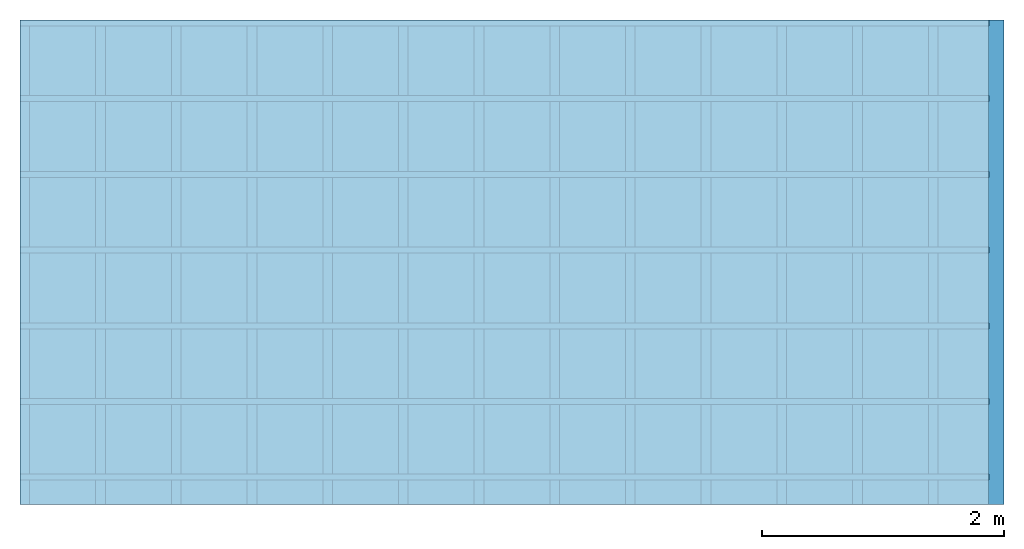
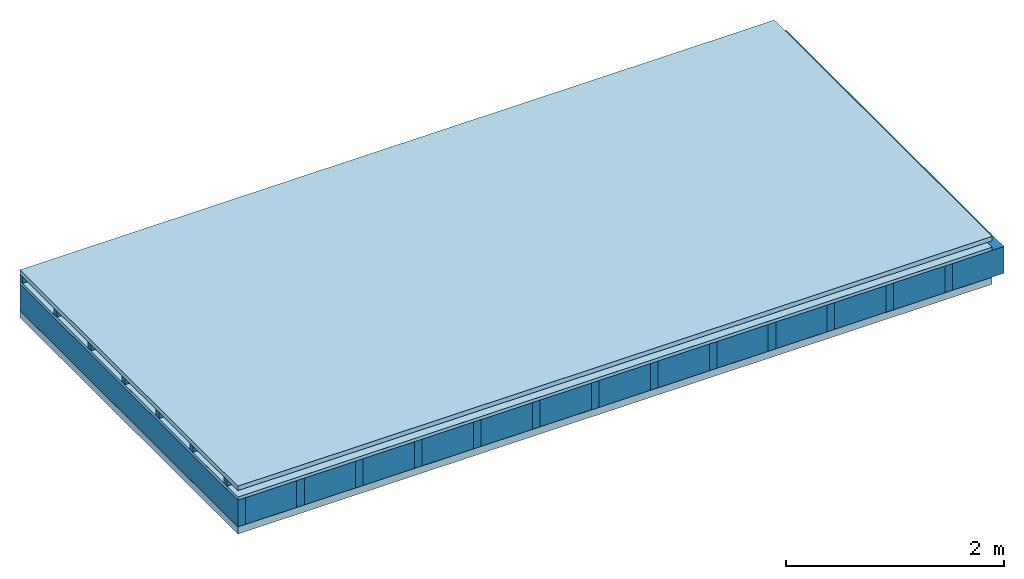
# One storey: 5 plates, 3 members, 1 element without a shape of its own.
"""IFC4 building model written with IfcOpenShell, lengths in metres."""

from ifc_helpers import new_model, si_unit, derived_unit, direction, frame, frame_2d, origin, origin_with_axes, place, context, project, spatial, rectangle, extrude, material, layer, layer_set, type_object, element, aggregate, save


model = new_model("IFC4")

# Units and contexts
plan_context = context("Plan", 3, precision=1e-05, world=origin(), true_north=direction((0.0, 1.0)))
model_context = context("Model", 3, precision=1e-05, world=origin(), true_north=direction((0.0, 1.0)))
ifc_project = project(units=[si_unit("LENGTHUNIT", "METRE"), derived_unit("SOUNDPRESSUREUNIT", [(si_unit("PRESSUREUNIT", "PASCAL", prefix="MICRO"), 0)]), si_unit("ENERGYUNIT", "JOULE", prefix="MEGA"), si_unit("MASSUNIT", "GRAM", prefix="KILO"), derived_unit("THERMALTRANSMITTANCEUNIT", [(si_unit("POWERUNIT", "WATT"), 1), (si_unit("AREAUNIT", "SQUARE_METRE"), -1), (si_unit("THERMODYNAMICTEMPERATUREUNIT", "KELVIN"), -1)]), derived_unit("AREADENSITYUNIT", [(si_unit("MASSUNIT", "GRAM", prefix="KILO"), 1), (si_unit("AREAUNIT", "SQUARE_METRE"), -1)]), derived_unit("USERDEFINED", [(si_unit("ENERGYUNIT", "JOULE", prefix="MEGA"), 1), (si_unit("AREAUNIT", "SQUARE_METRE"), -1)])], contexts=[plan_context, model_context])

# Site, building, storey
site = spatial("IfcSite", under=ifc_project)
building_placement = place(None, origin())
building = spatial("IfcBuilding", under=site, at=building_placement)
storey_placement = place(building_placement, origin())
storey = spatial("IfcBuildingStorey", under=building, at=storey_placement)

# Slab, members, plates
ifc_material_1 = material(Name="Roof tiles", Category="03.015")
ifc_layer_1 = layer(ifc_material_1, 0.05, Name="Roofing")
ifc_layer_2 = layer(None, 0.072, Name="Battens / profiles")
ifc_material_2 = material(Name="Roofing underlay", Category="09.008")
ifc_layer_3 = layer(ifc_material_2, 0.00018, Name="Under the roof")
ifc_material_3 = material(Category="10.009")
ifc_layer_4 = layer(ifc_material_3, 0.035, Name="Sub-floor")
ifc_material_4 = material(Name="of the art")
ifc_layer_5 = layer(ifc_material_4, 0.0, Name="Bond")
ifc_layer_6 = layer(None, 0.3, Name="Supporting structure")
ifc_material_5 = material(Name="Vapor barrier polyethylene (PE)", Category="09.002")
ifc_layer_7 = layer(ifc_material_5, 0.00025, Name="Lower layer 1")
ifc_material_6 = material(Name="Solid timber panel")
ifc_layer_8 = layer(ifc_material_6, 0.08, Name="Lower 2nd layer")
ifc_layer_set = layer_set([ifc_layer_1, ifc_layer_2, ifc_layer_3, ifc_layer_4, ifc_layer_5, ifc_layer_6, ifc_layer_7, ifc_layer_8])
slab_type = type_object("IfcSlabType", Name="E0155", PredefinedType="NOTDEFINED", material=ifc_layer_set)
slab_placement = place(None, frame((0.0, 0.0, 0.0), z_axis=(0.0, 0.0, -1.0), x_axis=(1.0, 0.0, 0.0)))
slab = element("IfcSlab", 1, at=slab_placement, inside=storey, type_object=slab_type, material=ifc_layer_set, Name="Slab #1")
ifc_material_7 = material()
member_1_placement = place(slab_placement, origin())
member_1 = element("IfcMember", 2, at=member_1_placement, material=ifc_material_7, Name="Battens / profiles", context=plan_context, shape_type="SweptSolid", body=[
    extrude(rectangle(XDim=0.05, YDim=0.072, at=frame_2d((0.025, 0.036), x_axis=(1.0, 0.0))), frame((0.0, 0.0, 0.05), z_axis=(1.0, 0.0, 0.0), x_axis=(0.0, 1.0, 0.0)), (0.0, 0.0, 1.0), 8.0),
    extrude(rectangle(XDim=0.05, YDim=0.072, at=frame_2d((0.025, 0.036), x_axis=(1.0, 0.0))), frame((0.0, 0.625, 0.05), z_axis=(1.0, 0.0, 0.0), x_axis=(0.0, 1.0, 0.0)), (0.0, 0.0, 1.0), 8.0),
    extrude(rectangle(XDim=0.05, YDim=0.072, at=frame_2d((0.025, 0.036), x_axis=(1.0, 0.0))), frame((0.0, 1.25, 0.05), z_axis=(1.0, 0.0, 0.0), x_axis=(0.0, 1.0, 0.0)), (0.0, 0.0, 1.0), 8.0),
    extrude(rectangle(XDim=0.05, YDim=0.072, at=frame_2d((0.025, 0.036), x_axis=(1.0, 0.0))), frame((0.0, 1.875, 0.05), z_axis=(1.0, 0.0, 0.0), x_axis=(0.0, 1.0, 0.0)), (0.0, 0.0, 1.0), 8.0),
    extrude(rectangle(XDim=0.05, YDim=0.072, at=frame_2d((0.025, 0.036), x_axis=(1.0, 0.0))), frame((0.0, 2.5, 0.05), z_axis=(1.0, 0.0, 0.0), x_axis=(0.0, 1.0, 0.0)), (0.0, 0.0, 1.0), 8.0),
    extrude(rectangle(XDim=0.05, YDim=0.072, at=frame_2d((0.025, 0.036), x_axis=(1.0, 0.0))), frame((0.0, 3.125, 0.05), z_axis=(1.0, 0.0, 0.0), x_axis=(0.0, 1.0, 0.0)), (0.0, 0.0, 1.0), 8.0),
    extrude(rectangle(XDim=0.05, YDim=0.072, at=frame_2d((0.025, 0.036), x_axis=(1.0, 0.0))), frame((0.0, 3.75, 0.05), z_axis=(1.0, 0.0, 0.0), x_axis=(0.0, 1.0, 0.0)), (0.0, 0.0, 1.0), 8.0),
])
ifc_material_8 = material()
member_2_placement = place(slab_placement, origin())
member_2 = element("IfcMember", 3, at=member_2_placement, material=ifc_material_8, Name="Supporting structure", context=plan_context, shape_type="SweptSolid", body=[
    extrude(rectangle(XDim=0.08, YDim=0.3, at=frame_2d((0.04, 0.15), x_axis=(1.0, 0.0))), frame((0.0, 4.0, 0.15718), z_axis=(0.0, -1.0, 0.0), x_axis=(1.0, 0.0, 0.0)), (0.0, 0.0, 1.0), 4.0),
    extrude(rectangle(XDim=0.08, YDim=0.3, at=frame_2d((0.04, 0.15), x_axis=(1.0, 0.0))), frame((0.625, 4.0, 0.15718), z_axis=(0.0, -1.0, 0.0), x_axis=(1.0, 0.0, 0.0)), (0.0, 0.0, 1.0), 4.0),
    extrude(rectangle(XDim=0.08, YDim=0.3, at=frame_2d((0.04, 0.15), x_axis=(1.0, 0.0))), frame((1.25, 4.0, 0.15718), z_axis=(0.0, -1.0, 0.0), x_axis=(1.0, 0.0, 0.0)), (0.0, 0.0, 1.0), 4.0),
    extrude(rectangle(XDim=0.08, YDim=0.3, at=frame_2d((0.04, 0.15), x_axis=(1.0, 0.0))), frame((1.875, 4.0, 0.15718), z_axis=(0.0, -1.0, 0.0), x_axis=(1.0, 0.0, 0.0)), (0.0, 0.0, 1.0), 4.0),
    extrude(rectangle(XDim=0.08, YDim=0.3, at=frame_2d((0.04, 0.15), x_axis=(1.0, 0.0))), frame((2.5, 4.0, 0.15718), z_axis=(0.0, -1.0, 0.0), x_axis=(1.0, 0.0, 0.0)), (0.0, 0.0, 1.0), 4.0),
    extrude(rectangle(XDim=0.08, YDim=0.3, at=frame_2d((0.04, 0.15), x_axis=(1.0, 0.0))), frame((3.125, 4.0, 0.15718), z_axis=(0.0, -1.0, 0.0), x_axis=(1.0, 0.0, 0.0)), (0.0, 0.0, 1.0), 4.0),
    extrude(rectangle(XDim=0.08, YDim=0.3, at=frame_2d((0.04, 0.15), x_axis=(1.0, 0.0))), frame((3.75, 4.0, 0.15718), z_axis=(0.0, -1.0, 0.0), x_axis=(1.0, 0.0, 0.0)), (0.0, 0.0, 1.0), 4.0),
    extrude(rectangle(XDim=0.08, YDim=0.3, at=frame_2d((0.04, 0.15), x_axis=(1.0, 0.0))), frame((4.375, 4.0, 0.15718), z_axis=(0.0, -1.0, 0.0), x_axis=(1.0, 0.0, 0.0)), (0.0, 0.0, 1.0), 4.0),
    extrude(rectangle(XDim=0.08, YDim=0.3, at=frame_2d((0.04, 0.15), x_axis=(1.0, 0.0))), frame((5.0, 4.0, 0.15718), z_axis=(0.0, -1.0, 0.0), x_axis=(1.0, 0.0, 0.0)), (0.0, 0.0, 1.0), 4.0),
    extrude(rectangle(XDim=0.08, YDim=0.3, at=frame_2d((0.04, 0.15), x_axis=(1.0, 0.0))), frame((5.625, 4.0, 0.15718), z_axis=(0.0, -1.0, 0.0), x_axis=(1.0, 0.0, 0.0)), (0.0, 0.0, 1.0), 4.0),
    extrude(rectangle(XDim=0.08, YDim=0.3, at=frame_2d((0.04, 0.15), x_axis=(1.0, 0.0))), frame((6.25, 4.0, 0.15718), z_axis=(0.0, -1.0, 0.0), x_axis=(1.0, 0.0, 0.0)), (0.0, 0.0, 1.0), 4.0),
    extrude(rectangle(XDim=0.08, YDim=0.3, at=frame_2d((0.04, 0.15), x_axis=(1.0, 0.0))), frame((6.875, 4.0, 0.15718), z_axis=(0.0, -1.0, 0.0), x_axis=(1.0, 0.0, 0.0)), (0.0, 0.0, 1.0), 4.0),
    extrude(rectangle(XDim=0.08, YDim=0.3, at=frame_2d((0.04, 0.15), x_axis=(1.0, 0.0))), frame((7.5, 4.0, 0.15718), z_axis=(0.0, -1.0, 0.0), x_axis=(1.0, 0.0, 0.0)), (0.0, 0.0, 1.0), 4.0),
])
ifc_material_9 = material(Name="Mineral wool")
member_3_placement = place(slab_placement, origin())
member_3 = element("IfcMember", 4, at=member_3_placement, material=ifc_material_9, Name="Cavity", context=plan_context, shape_type="SweptSolid", body=[
    extrude(rectangle(XDim=0.545, YDim=0.3, at=frame_2d((0.2725, 0.15), x_axis=(1.0, 0.0))), frame((0.08, 4.0, 0.15718), z_axis=(0.0, -1.0, 0.0), x_axis=(1.0, 0.0, 0.0)), (0.0, 0.0, 1.0), 4.0),
    extrude(rectangle(XDim=0.545, YDim=0.3, at=frame_2d((0.2725, 0.15), x_axis=(1.0, 0.0))), frame((0.705, 4.0, 0.15718), z_axis=(0.0, -1.0, 0.0), x_axis=(1.0, 0.0, 0.0)), (0.0, 0.0, 1.0), 4.0),
    extrude(rectangle(XDim=0.545, YDim=0.3, at=frame_2d((0.2725, 0.15), x_axis=(1.0, 0.0))), frame((1.33, 4.0, 0.15718), z_axis=(0.0, -1.0, 0.0), x_axis=(1.0, 0.0, 0.0)), (0.0, 0.0, 1.0), 4.0),
    extrude(rectangle(XDim=0.545, YDim=0.3, at=frame_2d((0.2725, 0.15), x_axis=(1.0, 0.0))), frame((1.955, 4.0, 0.15718), z_axis=(0.0, -1.0, 0.0), x_axis=(1.0, 0.0, 0.0)), (0.0, 0.0, 1.0), 4.0),
    extrude(rectangle(XDim=0.545, YDim=0.3, at=frame_2d((0.2725, 0.15), x_axis=(1.0, 0.0))), frame((2.58, 4.0, 0.15718), z_axis=(0.0, -1.0, 0.0), x_axis=(1.0, 0.0, 0.0)), (0.0, 0.0, 1.0), 4.0),
    extrude(rectangle(XDim=0.545, YDim=0.3, at=frame_2d((0.2725, 0.15), x_axis=(1.0, 0.0))), frame((3.205, 4.0, 0.15718), z_axis=(0.0, -1.0, 0.0), x_axis=(1.0, 0.0, 0.0)), (0.0, 0.0, 1.0), 4.0),
    extrude(rectangle(XDim=0.545, YDim=0.3, at=frame_2d((0.2725, 0.15), x_axis=(1.0, 0.0))), frame((3.83, 4.0, 0.15718), z_axis=(0.0, -1.0, 0.0), x_axis=(1.0, 0.0, 0.0)), (0.0, 0.0, 1.0), 4.0),
    extrude(rectangle(XDim=0.545, YDim=0.3, at=frame_2d((0.2725, 0.15), x_axis=(1.0, 0.0))), frame((4.455, 4.0, 0.15718), z_axis=(0.0, -1.0, 0.0), x_axis=(1.0, 0.0, 0.0)), (0.0, 0.0, 1.0), 4.0),
    extrude(rectangle(XDim=0.545, YDim=0.3, at=frame_2d((0.2725, 0.15), x_axis=(1.0, 0.0))), frame((5.08, 4.0, 0.15718), z_axis=(0.0, -1.0, 0.0), x_axis=(1.0, 0.0, 0.0)), (0.0, 0.0, 1.0), 4.0),
    extrude(rectangle(XDim=0.545, YDim=0.3, at=frame_2d((0.2725, 0.15), x_axis=(1.0, 0.0))), frame((5.705, 4.0, 0.15718), z_axis=(0.0, -1.0, 0.0), x_axis=(1.0, 0.0, 0.0)), (0.0, 0.0, 1.0), 4.0),
    extrude(rectangle(XDim=0.545, YDim=0.3, at=frame_2d((0.2725, 0.15), x_axis=(1.0, 0.0))), frame((6.33, 4.0, 0.15718), z_axis=(0.0, -1.0, 0.0), x_axis=(1.0, 0.0, 0.0)), (0.0, 0.0, 1.0), 4.0),
    extrude(rectangle(XDim=0.545, YDim=0.3, at=frame_2d((0.2725, 0.15), x_axis=(1.0, 0.0))), frame((6.955, 4.0, 0.15718), z_axis=(0.0, -1.0, 0.0), x_axis=(1.0, 0.0, 0.0)), (0.0, 0.0, 1.0), 4.0),
    extrude(rectangle(XDim=0.545, YDim=0.3, at=frame_2d((0.2725, 0.15), x_axis=(1.0, 0.0))), frame((7.58, 4.0, 0.15718), z_axis=(0.0, -1.0, 0.0), x_axis=(1.0, 0.0, 0.0)), (0.0, 0.0, 1.0), 4.0),
])
plate_1_placement = place(slab_placement, origin())
plate_1 = element("IfcPlate", 5, at=plate_1_placement, material=ifc_material_1, Name="Roofing", context=plan_context, shape_type="SweptSolid", body=[
    extrude(rectangle(XDim=8.0, YDim=4.0, at=frame_2d((4.0, 2.0), x_axis=(1.0, 0.0))), origin_with_axes(), (0.0, 0.0, 1.0), 0.05),
])
plate_2_placement = place(slab_placement, origin())
plate_2 = element("IfcPlate", 6, at=plate_2_placement, material=ifc_material_2, Name="Under the roof", context=plan_context, shape_type="SweptSolid", body=[
    extrude(rectangle(XDim=8.0, YDim=4.0, at=frame_2d((4.0, 2.0), x_axis=(1.0, 0.0))), frame((0.0, 0.0, 0.122), z_axis=(0.0, 0.0, 1.0), x_axis=(1.0, 0.0, 0.0)), (0.0, 0.0, 1.0), 0.00018),
])
plate_3_placement = place(slab_placement, origin())
plate_3 = element("IfcPlate", 7, at=plate_3_placement, material=ifc_material_3, Name="Sub-floor", context=plan_context, shape_type="SweptSolid", body=[
    extrude(rectangle(XDim=8.0, YDim=4.0, at=frame_2d((4.0, 2.0), x_axis=(1.0, 0.0))), frame((0.0, 0.0, 0.12218), z_axis=(0.0, 0.0, 1.0), x_axis=(1.0, 0.0, 0.0)), (0.0, 0.0, 1.0), 0.035),
])
plate_4_placement = place(slab_placement, origin())
plate_4 = element("IfcPlate", 8, at=plate_4_placement, material=ifc_material_5, Name="Lower layer 1", context=plan_context, shape_type="SweptSolid", body=[
    extrude(rectangle(XDim=8.0, YDim=4.0, at=frame_2d((4.0, 2.0), x_axis=(1.0, 0.0))), frame((0.0, 0.0, 0.45718), z_axis=(0.0, 0.0, 1.0), x_axis=(1.0, 0.0, 0.0)), (0.0, 0.0, 1.0), 0.00025),
])
plate_5_placement = place(slab_placement, origin())
plate_5 = element("IfcPlate", 9, at=plate_5_placement, material=ifc_material_6, Name="Lower 2nd layer", context=plan_context, shape_type="SweptSolid", body=[
    extrude(rectangle(XDim=8.0, YDim=4.0, at=frame_2d((4.0, 2.0), x_axis=(1.0, 0.0))), frame((0.0, 0.0, 0.45743), z_axis=(0.0, 0.0, 1.0), x_axis=(1.0, 0.0, 0.0)), (0.0, 0.0, 1.0), 0.08),
])
aggregate(slab, [plate_1, member_1, plate_2, plate_3, member_2, member_3, plate_4, plate_5])

save(model, "model.ifc")
